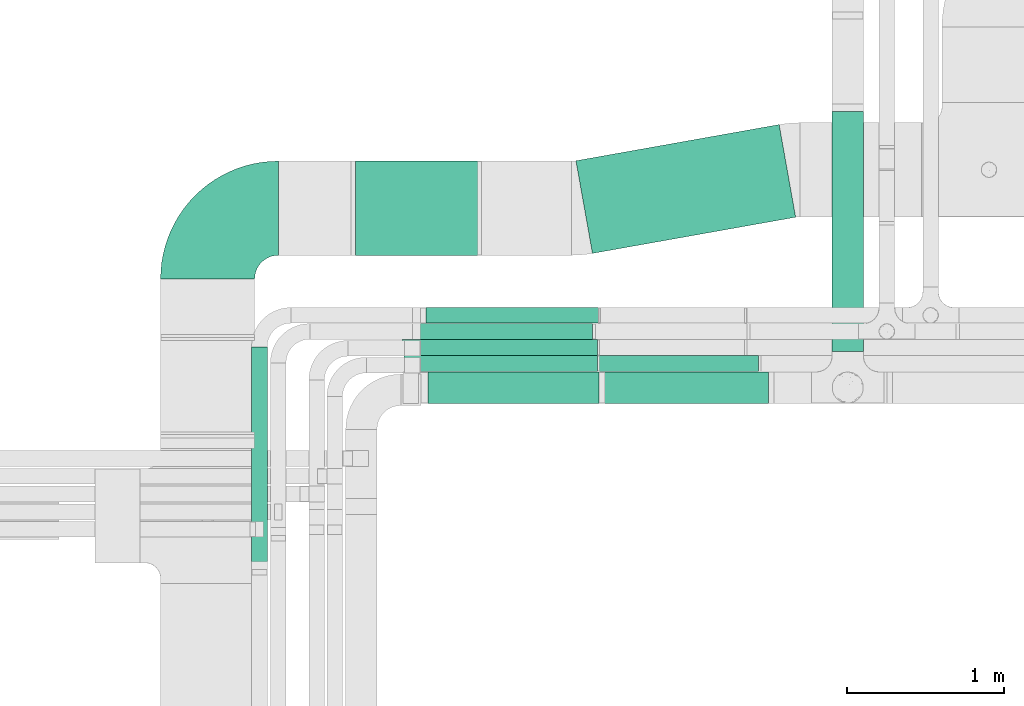
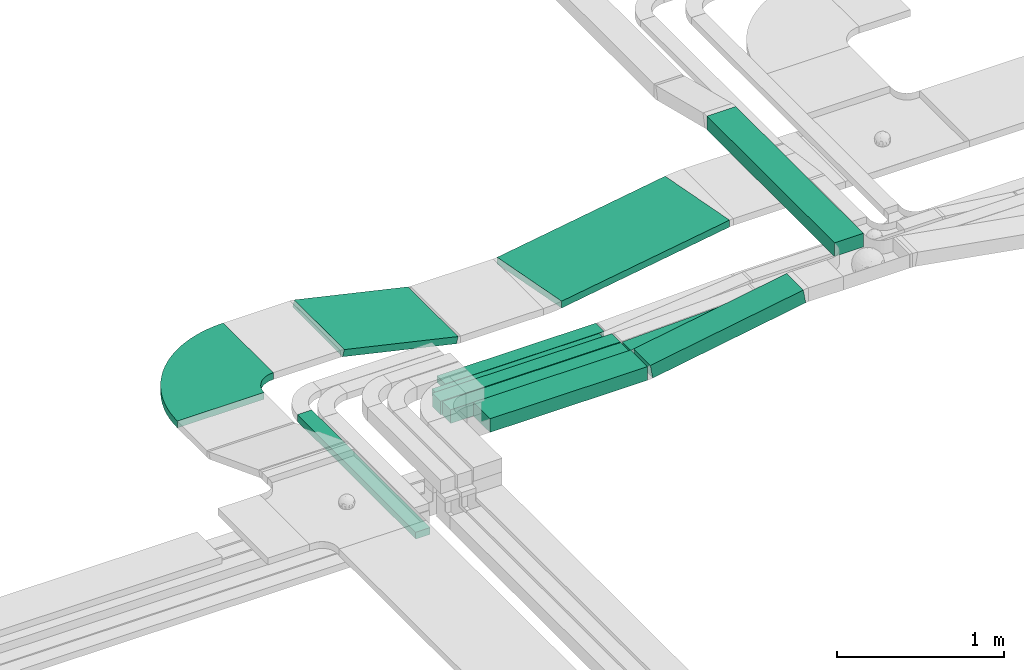
# One storey, part 3 of 38: 11 flow segments, 1 flow fitting.
"""IFC2X3 building model written with IfcOpenShell, lengths in millimetres."""

import ifcopenshell
import ifcopenshell.guid

model = None  # the IFC model being written
_history = None  # IfcOwnerHistory: only IFC2X3 demands one
_inside = {}  # id of a spatial element -> (the spatial element, [elements in it])
_under = {}  # id of a project, library or spatial element -> (it, [spatial elements below it])
_declared = {}  # id of a project -> (the project, [libraries it declares])
_typed = {}  # id of a type object -> (the type object, [elements of that type])
_made_of = {}  # id of a material, layer set ... -> (it, [elements and type objects made of it])


def new_model(schema):
    """Start an empty IFC model of exactly this schema.

    Asked for "IFC4X3", IfcOpenShell would pick the latest addendum, in which some entities
    have other attributes; the version numbers below select the first issue.
    IFC2X3 requires an IfcOwnerHistory on every rooted entity: one is made here for all.
    """
    global model, _history
    if schema == "IFC4X3":
        model = ifcopenshell.file(schema_version=(4, 3, 0, 0))
    else:
        model = ifcopenshell.file(schema=schema)
    _inside.clear()
    _under.clear()
    _declared.clear()
    _typed.clear()
    _made_of.clear()
    _history = None
    if model.schema == "IFC2X3":
        org = make("IfcOrganization", Name="unknown")
        user = make(
            "IfcPersonAndOrganization",
            ThePerson=make("IfcPerson", FamilyName="unknown"),
            TheOrganization=org,
        )
        app = make(
            "IfcApplication",
            ApplicationDeveloper=org,
            Version="unknown",
            ApplicationFullName="unknown",
            ApplicationIdentifier="unknown",
        )
        _history = make(
            "IfcOwnerHistory",
            OwningUser=user,
            OwningApplication=app,
            ChangeAction="ADDED",
            CreationDate=0,
        )
    return model


def make(cls, **values):
    """One entity of the class cls with the attributes given. An attribute that is None is left unset."""
    return model.create_entity(
        cls, **{name: value for name, value in values.items() if value is not None}
    )


def entity(cls, *values):
    """Any entity or typed value of the class cls, its attributes in the order of the schema. None: left unset."""
    e = model.create_entity(cls)
    for i, value in enumerate(values):
        if value is not None:
            e[i] = value
    return e


def rooted(cls, **values):
    """An entity with a GlobalId (a new one), such as an element, a storey or a relation."""
    return make(cls, GlobalId=ifcopenshell.guid.new(), OwnerHistory=_history, **values)


def si_unit(unit_type, name, prefix=None):
    """IfcSIUnit, for example si_unit("LENGTHUNIT", "METRE", prefix="MILLI")."""
    return make("IfcSIUnit", UnitType=unit_type, Prefix=prefix, Name=name)


def converted_unit(unit_type, name, factor, base, dimensions=None, offset=None):
    """IfcConversionBasedUnit, such as the inch: factor (a typed value) times the base unit."""
    return make(
        "IfcConversionBasedUnit"
        if offset is None
        else "IfcConversionBasedUnitWithOffset",
        ConversionOffset=offset,
        Dimensions=None
        if dimensions is None
        else entity("IfcDimensionalExponents", *dimensions),
        UnitType=unit_type,
        Name=name,
        ConversionFactor=make(
            "IfcMeasureWithUnit", ValueComponent=factor, UnitComponent=base
        ),
    )


def derived_unit(unit_type, elements):
    """IfcDerivedUnit: a product of units, each with its exponent."""
    return make(
        "IfcDerivedUnit",
        Elements=[
            make("IfcDerivedUnitElement", Unit=unit, Exponent=power)
            for unit, power in elements
        ],
        UnitType=unit_type,
    )


def assignment(units):
    """IfcUnitAssignment: the units of a project."""
    return None if units is None else make("IfcUnitAssignment", Units=units)


def point(xyz):
    """IfcCartesianPoint."""
    return None if xyz is None else make("IfcCartesianPoint", Coordinates=xyz)


def direction(xyz):
    """IfcDirection."""
    return None if xyz is None else make("IfcDirection", DirectionRatios=xyz)


def frame(location, z_axis=None, x_axis=None):
    """IfcAxis2Placement3D, a coordinate frame: its origin and axes. An axis left out is left unset."""
    return make(
        "IfcAxis2Placement3D",
        Location=point(location),
        Axis=direction(z_axis),
        RefDirection=direction(x_axis),
    )


def frame_2d(location, x_axis=None):
    """IfcAxis2Placement2D, a coordinate frame in the plane: its origin and x axis."""
    return make(
        "IfcAxis2Placement2D", Location=point(location), RefDirection=direction(x_axis)
    )


def origin():
    """The frame at (0, 0, 0) with its axes left unset."""
    return frame((0.0, 0.0, 0.0))


def origin_2d_with_axis():
    """The frame at (0, 0) in the plane with the x axis (1, 0) written out."""
    return frame_2d((0.0, 0.0), x_axis=(1.0, 0.0))


def place(relative_to, where):
    """IfcLocalPlacement: puts the frame where relative to a parent placement (None: the world)."""
    return make(
        "IfcLocalPlacement", PlacementRelTo=relative_to, RelativePlacement=where
    )


def context(
    kind, dimensions, precision=None, world=None, true_north=None, identifier=None
):
    """IfcGeometricRepresentationContext, for example the 3D "Model" context."""
    return make(
        "IfcGeometricRepresentationContext",
        ContextIdentifier=identifier,
        ContextType=kind,
        CoordinateSpaceDimension=dimensions,
        Precision=precision,
        WorldCoordinateSystem=world,
        TrueNorth=true_north,
    )


def subcontext(parent, identifier, kind, view, scale=None):
    """IfcGeometricRepresentationSubContext, for example "Body" below "Model"."""
    return make(
        "IfcGeometricRepresentationSubContext",
        ContextIdentifier=identifier,
        ContextType=kind,
        ParentContext=parent,
        TargetScale=scale,
        TargetView=view,
    )


def project(units=None, contexts=None):
    """IfcProject with its units and contexts."""
    return rooted(
        "IfcProject",
        Name="project",
        RepresentationContexts=contexts,
        UnitsInContext=assignment(units),
    )


def spatial(cls, under=None, at=None, **own):
    """A site, building, storey or space (cls), placed at a placement, below another one or the project."""
    s = rooted(cls, ObjectPlacement=at, **own)
    if under is not None:
        _under.setdefault(under.id(), (under, []))[1].append(s)
    return s


def polyline(points):
    """IfcPolyline through the points."""
    return make("IfcPolyline", Points=[point(p) for p in points])


def circle_curve(where, radius):
    """IfcCircle in the frame where."""
    return make("IfcCircle", Position=where, Radius=radius)


def parameter(value):
    """IfcParameterValue: where a trimmed curve begins or ends, as a parameter of its basis curve."""
    return model.create_entity("IfcParameterValue", value)


def trimmed(basis, trim1, trim2, sense, master):
    """IfcTrimmedCurve: the piece of a basis curve between two trims."""
    return make(
        "IfcTrimmedCurve",
        BasisCurve=basis,
        Trim1=trim1,
        Trim2=trim2,
        SenseAgreement=sense,
        MasterRepresentation=master,
    )


def segment(curve, same_sense, transition):
    """IfcCompositeCurveSegment."""
    return make(
        "IfcCompositeCurveSegment",
        Transition=transition,
        SameSense=same_sense,
        ParentCurve=curve,
    )


def composite_curve(segments, self_intersect=None):
    """IfcCompositeCurve: segments joined end to end."""
    return make("IfcCompositeCurve", Segments=segments, SelfIntersect=self_intersect)


def profile(cls, at=None, kind="AREA", **sizes):
    """A parametric profile (cls). Its sizes go by their IFC names, for example OverallWidth=200.0."""
    return make(cls, ProfileType=kind, Position=at, **sizes)


def rectangle(**sizes):
    """IfcRectangleProfileDef."""
    return profile("IfcRectangleProfileDef", **sizes)


def outline(outer, holes=None, kind="AREA"):
    """IfcArbitraryClosedProfileDef: a profile drawn as a closed curve; with holes, ...WithVoids."""
    if holes is None:
        return make("IfcArbitraryClosedProfileDef", ProfileType=kind, OuterCurve=outer)
    return make(
        "IfcArbitraryProfileDefWithVoids",
        ProfileType=kind,
        OuterCurve=outer,
        InnerCurves=holes,
    )


def extrude(swept, where, along, depth):
    """IfcExtrudedAreaSolid: the profile swept, set in the frame where, extruded along a direction by depth."""
    return make(
        "IfcExtrudedAreaSolid",
        SweptArea=swept,
        Position=where,
        ExtrudedDirection=direction(along),
        Depth=depth,
    )


def shape(context_of_items, identifier, shape_type, items):
    """IfcShapeRepresentation: the items that make up one representation, for example the "Body"."""
    return make(
        "IfcShapeRepresentation",
        ContextOfItems=context_of_items,
        RepresentationIdentifier=identifier,
        RepresentationType=shape_type,
        Items=items,
    )


def source(mapping_origin, context_of_items, identifier, shape_type, items):
    """IfcRepresentationMap: a shape defined once, which mapped items show again and again."""
    return make(
        "IfcRepresentationMap",
        MappingOrigin=mapping_origin,
        MappedRepresentation=shape(context_of_items, identifier, shape_type, items),
    )


def transform(
    local_origin,
    x_axis=None,
    y_axis=None,
    z_axis=None,
    scale=None,
    scale2=None,
    scale3=None,
    uniform=True,
):
    """IfcCartesianTransformationOperator3D, or its non-uniform kind. x_axis, y_axis, z_axis: its Axis1, 2, 3."""
    if uniform:
        return make(
            "IfcCartesianTransformationOperator3D",
            Axis1=direction(x_axis),
            Axis2=direction(y_axis),
            LocalOrigin=point(local_origin),
            Scale=scale,
            Axis3=direction(z_axis),
        )
    return make(
        "IfcCartesianTransformationOperator3DnonUniform",
        Axis1=direction(x_axis),
        Axis2=direction(y_axis),
        LocalOrigin=point(local_origin),
        Scale=scale,
        Axis3=direction(z_axis),
        Scale2=scale2,
        Scale3=scale3,
    )


def mapped(mapping_source, mapping_target):
    """IfcMappedItem: shows the shape of a source again, moved by a transform."""
    return make(
        "IfcMappedItem", MappingSource=mapping_source, MappingTarget=mapping_target
    )


def material(Name=None, Category=None):
    """IfcMaterial."""
    return make("IfcMaterial", Name=Name, Category=Category)


def made_of(thing, what):
    """Note that an element or type object is made of a material, layer set ...; save() writes the relation."""
    if what is not None:
        _made_of.setdefault(what.id(), (what, []))[1].append(thing)
    return thing


def type_object(cls, material=None, **own):
    """A type object (cls), such as IfcWallType, which elements share."""
    return made_of(rooted(cls, **own), material)


def type_shapes(of_type, sources):
    """Give a type object the sources (RepresentationMaps) that its elements show as mapped items."""
    of_type.RepresentationMaps = sources


def element(
    cls,
    number,
    at=None,
    inside=None,
    cuts=None,
    type_object=None,
    material=None,
    context=None,
    identifier="Body",
    shape_type=None,
    held_by="IfcProductDefinitionShape",
    body=None,
    shapes=None,
    **own,
):
    """One element of the class cls, such as IfcWall. Its Tag is "e" and its number.

    at: its placement. inside: the storey or other place that contains it. cuts: it is an
    opening in that element (IfcRelVoidsElement). A single representation is given by context,
    identifier, shape_type and body (its items); several are given by shapes. held_by: the class
    of the entity that holds the representations. save() writes the other relations.
    """
    e = rooted(cls, Tag="e%d" % number, ObjectPlacement=at, **own)
    if body is not None:
        shapes = [shape(context, identifier, shape_type, body)]
    if shapes is not None:
        e.Representation = make(held_by, Representations=shapes)
    if inside is not None:
        _inside.setdefault(inside.id(), (inside, []))[1].append(e)
    if cuts is not None:
        rooted(
            "IfcRelVoidsElement", RelatingBuildingElement=cuts, RelatedOpeningElement=e
        )
    if type_object is not None:
        _typed.setdefault(type_object.id(), (type_object, []))[1].append(e)
    return made_of(e, material)


def aggregate(whole, parts):
    """IfcRelAggregates: a whole, such as a stair, and the parts it consists of."""
    return rooted("IfcRelAggregates", RelatingObject=whole, RelatedObjects=parts)


def save(model, path):
    """Write the relations noted so far, then the file.

    IfcRelAggregates (storeys below a building ...), IfcRelContainedInSpatialStructure (elements
    in a storey), IfcRelDefinesByType, IfcRelAssociatesMaterial and IfcRelDeclares: one each for
    every whole, place, type object, material and project.
    """
    for whole, parts in _under.values():
        aggregate(whole, parts)
    for where, things in _inside.values():
        rooted(
            "IfcRelContainedInSpatialStructure",
            RelatedElements=things,
            RelatingStructure=where,
        )
    for kind, things in _typed.values():
        rooted("IfcRelDefinesByType", RelatedObjects=things, RelatingType=kind)
    for what, things in _made_of.values():
        rooted("IfcRelAssociatesMaterial", RelatedObjects=things, RelatingMaterial=what)
    for by, libraries in _declared.values():
        rooted("IfcRelDeclares", RelatingContext=by, RelatedDefinitions=libraries)
    model.write(path)


model = new_model("IFC2X3")

# Units and contexts
model_context = context("Model", 3, precision=0.01, world=origin(), true_north=direction((6.12303176911189e-17, 1.0)))
body_context = subcontext(model_context, "Body", "Model", "MODEL_VIEW")
ifc_project = project(units=[si_unit("LENGTHUNIT", "METRE", prefix="MILLI"), si_unit("AREAUNIT", "SQUARE_METRE"), si_unit("VOLUMEUNIT", "CUBIC_METRE"), converted_unit("PLANEANGLEUNIT", "DEGREE", entity("IfcRatioMeasure", 0.0174532925199433), si_unit("PLANEANGLEUNIT", "RADIAN"), dimensions=[0, 0, 0, 0, 0, 0, 0]), si_unit("MASSUNIT", "GRAM", prefix="KILO"), derived_unit("MASSDENSITYUNIT", [(si_unit("MASSUNIT", "GRAM", prefix="KILO"), 1), (si_unit("LENGTHUNIT", "METRE"), -3)]), derived_unit("MOMENTOFINERTIAUNIT", [(si_unit("LENGTHUNIT", "METRE"), 4)]), si_unit("TIMEUNIT", "SECOND"), si_unit("FREQUENCYUNIT", "HERTZ"), si_unit("THERMODYNAMICTEMPERATUREUNIT", "DEGREE_CELSIUS"), derived_unit("THERMALTRANSMITTANCEUNIT", [(si_unit("MASSUNIT", "GRAM", prefix="KILO"), 1), (si_unit("THERMODYNAMICTEMPERATUREUNIT", "KELVIN"), -1), (si_unit("TIMEUNIT", "SECOND"), -3)]), derived_unit("VOLUMETRICFLOWRATEUNIT", [(si_unit("LENGTHUNIT", "METRE"), 3), (si_unit("TIMEUNIT", "SECOND"), -1)]), derived_unit("MASSFLOWRATEUNIT", [(si_unit("MASSUNIT", "GRAM", prefix="KILO"), 1), (si_unit("TIMEUNIT", "SECOND"), -1)]), derived_unit("ROTATIONALFREQUENCYUNIT", [(si_unit("TIMEUNIT", "SECOND"), -1)]), si_unit("ELECTRICCURRENTUNIT", "AMPERE"), si_unit("ELECTRICVOLTAGEUNIT", "VOLT"), si_unit("POWERUNIT", "WATT"), si_unit("FORCEUNIT", "NEWTON", prefix="KILO"), si_unit("ILLUMINANCEUNIT", "LUX"), si_unit("LUMINOUSFLUXUNIT", "LUMEN"), si_unit("LUMINOUSINTENSITYUNIT", "CANDELA"), derived_unit("USERDEFINED", [(si_unit("MASSUNIT", "GRAM", prefix="KILO"), -1), (si_unit("LENGTHUNIT", "METRE"), -2), (si_unit("TIMEUNIT", "SECOND"), 3), (si_unit("LUMINOUSFLUXUNIT", "LUMEN"), 1)]), derived_unit("LINEARVELOCITYUNIT", [(si_unit("LENGTHUNIT", "METRE"), 1), (si_unit("TIMEUNIT", "SECOND"), -1)]), si_unit("PRESSUREUNIT", "PASCAL"), derived_unit("USERDEFINED", [(si_unit("LENGTHUNIT", "METRE"), -2), (si_unit("MASSUNIT", "GRAM", prefix="KILO"), 1), (si_unit("TIMEUNIT", "SECOND"), -2)]), derived_unit("LINEARFORCEUNIT", [(si_unit("MASSUNIT", "GRAM", prefix="KILO"), 1), (si_unit("LENGTHUNIT", "METRE"), 1), (si_unit("TIMEUNIT", "SECOND"), -2), (si_unit("LENGTHUNIT", "METRE"), -1)]), derived_unit("PLANARFORCEUNIT", [(si_unit("MASSUNIT", "GRAM", prefix="KILO"), 1), (si_unit("LENGTHUNIT", "METRE"), 1), (si_unit("TIMEUNIT", "SECOND"), -2), (si_unit("LENGTHUNIT", "METRE"), -2)])], contexts=[model_context])

# Site, building, storey
site_placement = place(None, frame((0.0, -0.00077364408347762, 0.0)))
site = spatial("IfcSite", under=ifc_project, at=site_placement, CompositionType="ELEMENT")
building_placement = place(site_placement, origin())
building = spatial("IfcBuilding", under=site, at=building_placement, CompositionType="ELEMENT")
storey_placement = place(building_placement, frame((0.0, 0.0, 4200.0)))
storey = spatial("IfcBuildingStorey", under=building, at=storey_placement, CompositionType="ELEMENT", Elevation=4200.0)

# Flow segments
cable_carrier_segment_type = type_object("IfcCableCarrierSegmentType", PredefinedType="CABLETRAYSEGMENT")
flow_segment_1_placement = place(storey_placement, frame((14483.5407015969, 11773.7857236441, 2904.05791329438)))
element("IfcFlowSegment", 1, at=flow_segment_1_placement, inside=storey, type_object=cable_carrier_segment_type, context=body_context, shape_type="SweptSolid", body=[
    extrude(rectangle(XDim=1529.120177667, YDim=200.000000000002, at=origin_2d_with_axis()), frame((100.0, 764.560088833502, 0.0), z_axis=(0.0, 0.0, 1.0), x_axis=(0.0, 1.0, 0.0)), (0.0, 0.0, 1.0), 99.9999999999989),
])
flow_segment_2_placement = place(storey_placement, frame((12851.1157068465, 12398.8453503662, 2682.77089996955)))
element("IfcFlowSegment", 2, at=flow_segment_2_placement, inside=storey, type_object=cable_carrier_segment_type, context=body_context, shape_type="SweptSolid", body=[
    extrude(rectangle(XDim=1315.61202745931, YDim=600.000000000002, at=frame_2d((1.08002495835535e-12, -2.27373675443232e-13), x_axis=(1.0, 0.0))), frame((700.220590546798, 410.703151649985, 0.0), z_axis=(0.0, 0.0, 1.0), x_axis=(-0.98450467994016, -0.175358305123892, 0.0)), (0.0, 0.0, 1.0), 49.9999999999995),
])
flow_segment_3_placement = place(storey_placement, frame((13018.4608858182, 11443.7857236441, 2721.48591509025)))
element("IfcFlowSegment", 3, at=flow_segment_3_placement, inside=storey, type_object=cable_carrier_segment_type, context=body_context, shape_type="SweptSolid", body=[
    extrude(rectangle(XDim=100.0, YDim=200.000000000002, at=frame_2d((1.06581410364015e-12, 0.0), x_axis=(1.0, 0.0))), frame((8.421597513389, 100.0, 49.2856641968264), z_axis=(0.98571328393655, 0.0, 0.168431950267823), x_axis=(-0.168431950267823, 0.0, 0.98571328393655)), (0.0, 0.0, 1.0), 1074.28589873588),
])
flow_segment_4_placement = place(storey_placement, frame((11909.0911506353, 11443.7857236441, 2718.42931434907)))
element("IfcFlowSegment", 4, at=flow_segment_4_placement, inside=storey, type_object=cable_carrier_segment_type, context=body_context, shape_type="SweptSolid", body=[
    extrude(rectangle(XDim=1090.17741149844, YDim=199.999999999998, at=frame_2d((-1.08002495835535e-12, 0.0), x_axis=(1.0, 0.0))), frame((545.08870574922, 100.0, 0.0), z_axis=(0.0, 0.0, 1.0), x_axis=(-1.0, 0.0, 0.0)), (0.0, 0.0, 1.0), 99.9999999999989),
])
flow_segment_5_placement = place(storey_placement, frame((11434.3933369688, 12387.0485020162, 2685.90168213645)))
element("IfcFlowSegment", 5, at=flow_segment_5_placement, inside=storey, type_object=cable_carrier_segment_type, context=body_context, shape_type="SweptSolid", body=[
    extrude(rectangle(XDim=49.9999999999999, YDim=600.000000000002, at=frame_2d((0.0, 0.0), x_axis=(0.0, 1.0))), frame((5.57634932010804, 300.0, 204.654832030916), z_axis=(0.974806096214138, 0.0, -0.223053972804235), x_axis=(0.0, 1.0, 0.0)), (0.0, 0.0, 1.0), 808.25585556279),
])
flow_segment_6_placement = place(storey_placement, frame((11753.8201436942, 11646.8541189971, 2715.22575139994)))
element("IfcFlowSegment", 6, at=flow_segment_6_placement, inside=storey, type_object=cable_carrier_segment_type, context=body_context, shape_type="SweptSolid", body=[
    extrude(rectangle(XDim=1233.44098848929, YDim=99.9999999999989, at=frame_2d((1.08002495835535e-12, 0.0), x_axis=(1.0, 0.0))), frame((616.720494244647, 50.0, 0.0), z_axis=(0.0, 0.0, 1.0), x_axis=(-1.0, 0.0, 0.0)), (0.0, 0.0, 1.0), 99.9999999999989),
])
flow_segment_7_placement = place(storey_placement, frame((12999.1160304992, 11646.8541189971, 2715.48308332911)))
element("IfcFlowSegment", 7, at=flow_segment_7_placement, inside=storey, type_object=cable_carrier_segment_type, context=body_context, shape_type="SweptSolid", body=[
    extrude(rectangle(XDim=99.9999999999997, YDim=99.9999999999989, at=frame_2d((0.0, -1.08002495835535e-12), x_axis=(0.0, 1.0))), frame((1.68886490402554, 50.0, 49.9714692133026), z_axis=(0.999429384266034, 0.0, 0.0337772980804675), x_axis=(0.0, 1.0, 0.0)), (0.0, 0.0, 1.0), 1015.96777318739),
])
flow_segment_8_placement = place(storey_placement, frame((11743.8201436942, 11748.9581146252, 2718.4)))
element("IfcFlowSegment", 8, at=flow_segment_8_placement, inside=storey, type_object=cable_carrier_segment_type, context=body_context, shape_type="SweptSolid", body=[
    extrude(rectangle(XDim=1243.22618576762, YDim=99.9999999999989, at=origin_2d_with_axis()), frame((621.613092883809, 50.0, 0.0), z_axis=(0.0, 0.0, 1.0), x_axis=(-1.0, 0.0, 0.0)), (0.0, 0.0, 1.0), 99.9999999999989),
])
flow_segment_9_placement = place(storey_placement, frame((11800.866402396, 11851.5299176425, 2718.4)))
element("IfcFlowSegment", 9, at=flow_segment_9_placement, inside=storey, type_object=cable_carrier_segment_type, context=body_context, shape_type="SweptSolid", body=[
    extrude(rectangle(XDim=1157.17723915463, YDim=99.9999999999989, at=frame_2d((0.0, -1.08357767203415e-12), x_axis=(1.0, 0.0))), frame((578.588619577316, 50.0, 0.0), z_axis=(0.0, 0.0, 1.0), x_axis=(-1.0, 0.0, 0.0)), (0.0, 0.0, 1.0), 50.0000000000005),
])
flow_segment_10_placement = place(storey_placement, frame((11895.4915805971, 11954.0299176424, 2718.39999999998)))
element("IfcFlowSegment", 10, at=flow_segment_10_placement, inside=storey, type_object=cable_carrier_segment_type, context=body_context, shape_type="SweptSolid", body=[
    extrude(rectangle(XDim=1098.44771651259, YDim=99.9999999999989, at=origin_2d_with_axis()), frame((549.223858256294, 50.0, 0.0), z_axis=(0.0, 0.0, 1.0), x_axis=(-1.0, 0.0, 0.0)), (0.0, 0.0, 1.0), 49.9999999999995),
])
flow_segment_11_placement = place(storey_placement, frame((10783.5911506353, 10384.0299176425, 2975.0)))
element("IfcFlowSegment", 11, at=flow_segment_11_placement, inside=storey, type_object=cable_carrier_segment_type, context=body_context, shape_type="SweptSolid", body=[
    extrude(rectangle(XDim=1419.00000000001, YDim=99.9999999999989, at=frame_2d((-1.08002495835535e-12, -1.08357767203415e-12), x_axis=(1.0, 0.0))), frame((50.0, 709.500000000003, 0.0), z_axis=(0.0, 0.0, 1.0), x_axis=(0.0, -1.0, 0.0)), (0.0, 0.0, 1.0), 49.9999999999995),
])

# Flow fitting
ifc_material = material()
cable_carrier_fitting_type = type_object("IfcCableCarrierFittingType", Name="470_DKC_S5_Variable Angle Elbow 0-45:-", PredefinedType="NOTDEFINED", material=ifc_material)
shared_shape = source(origin(), body_context, "Body", "SweptSolid", [
    extrude(outline(composite_curve([segment(polyline([(-225.750000000019, -525.249999999993), (-224.750000000017, -525.249999999993)]), True, "CONTINUOUS"), segment(trimmed(circle_curve(frame_2d((-224.749999999992, 224.750000000007), x_axis=(0.0, -1.0)), 750.0), [parameter(0.0)], [parameter(90.0)], True, "PARAMETER"), True, "CONTINUOUS"), segment(polyline([(525.250000000007, 224.749999999983), (525.250000000007, 225.749999999979)]), True, "CONTINUOUS"), segment(polyline([(525.250000000007, 225.749999999979), (-74.7499999999926, 225.750000000006)]), True, "CONTINUOUS"), segment(polyline([(-74.7499999999926, 225.750000000006), (-74.7499999999927, 224.750000000002)]), True, "CONTINUOUS"), segment(trimmed(circle_curve(frame_2d((-224.749999999992, 224.750000000007), x_axis=(0.0, -1.0)), 150.0), [parameter(0.0)], [parameter(90.0000000000001)], True, "PARAMETER"), False, "CONTINUOUS"), segment(polyline([(-224.749999999996, 74.750000000007), (-225.749999999998, 74.750000000007)]), True, "CONTINUOUS"), segment(polyline([(-225.749999999998, 74.750000000007), (-225.750000000019, -525.249999999993)]), True, "CONTINUOUS")], self_intersect=False)), frame((-225.24999999999, 225.249999999992, -25.0)), (0.0, 0.0, 1.0), 50.0000000000082),
])
type_shapes(cable_carrier_fitting_type, [shared_shape])
flow_fitting_placement = place(storey_placement, frame((10503.5911506354, 12687.0485020162, 2893.05744873961), z_axis=(0.0, 0.0, 1.0), x_axis=(-1.0, 0.0, 0.0)))
element("IfcFlowFitting", 12, at=flow_fitting_placement, inside=storey, type_object=cable_carrier_fitting_type, material=ifc_material, Name="470_DKC_S5_Variable Angle Elbow 0-45:-", ObjectType="470_DKC_S5_Variable Angle Elbow 0-45:-", context=body_context, shape_type="MappedRepresentation", body=[
    mapped(shared_shape, transform((0.0, 0.0, 0.0), scale=1.0)),
])

save(model, "model.ifc")
